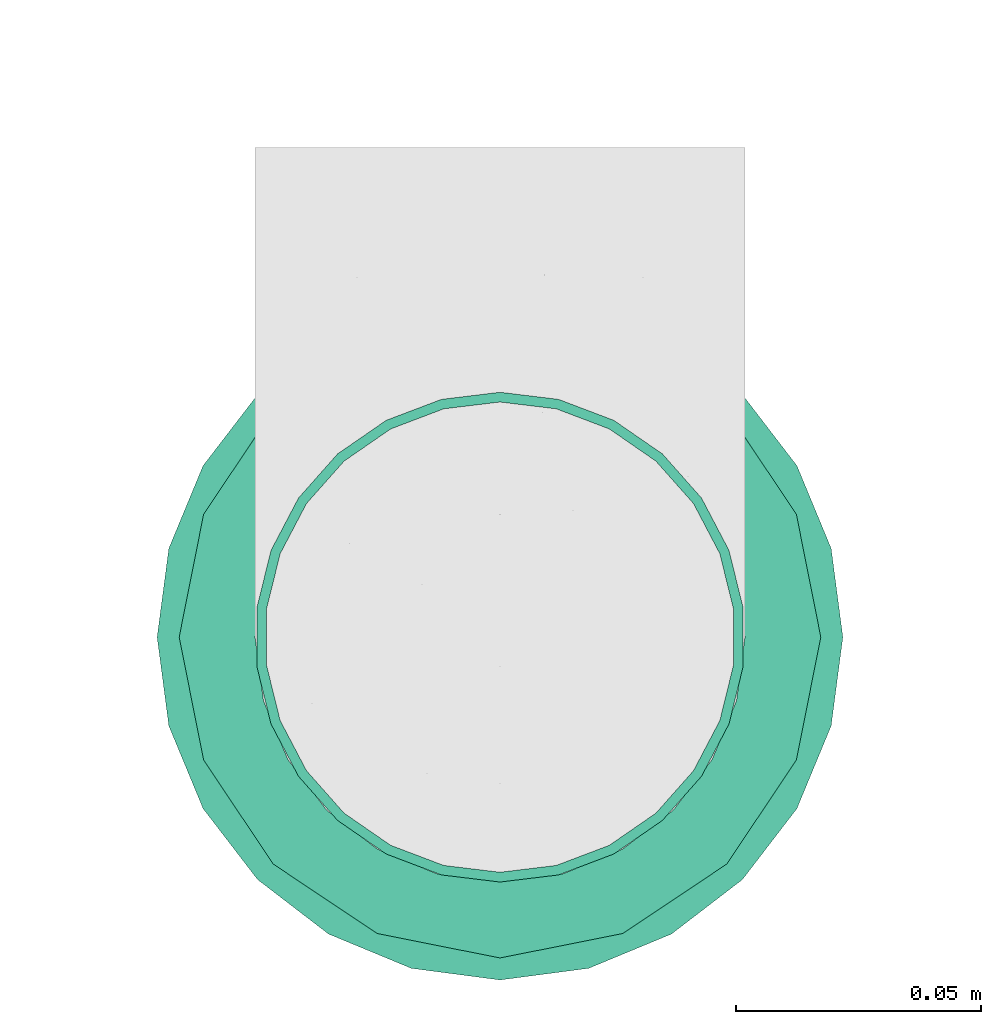
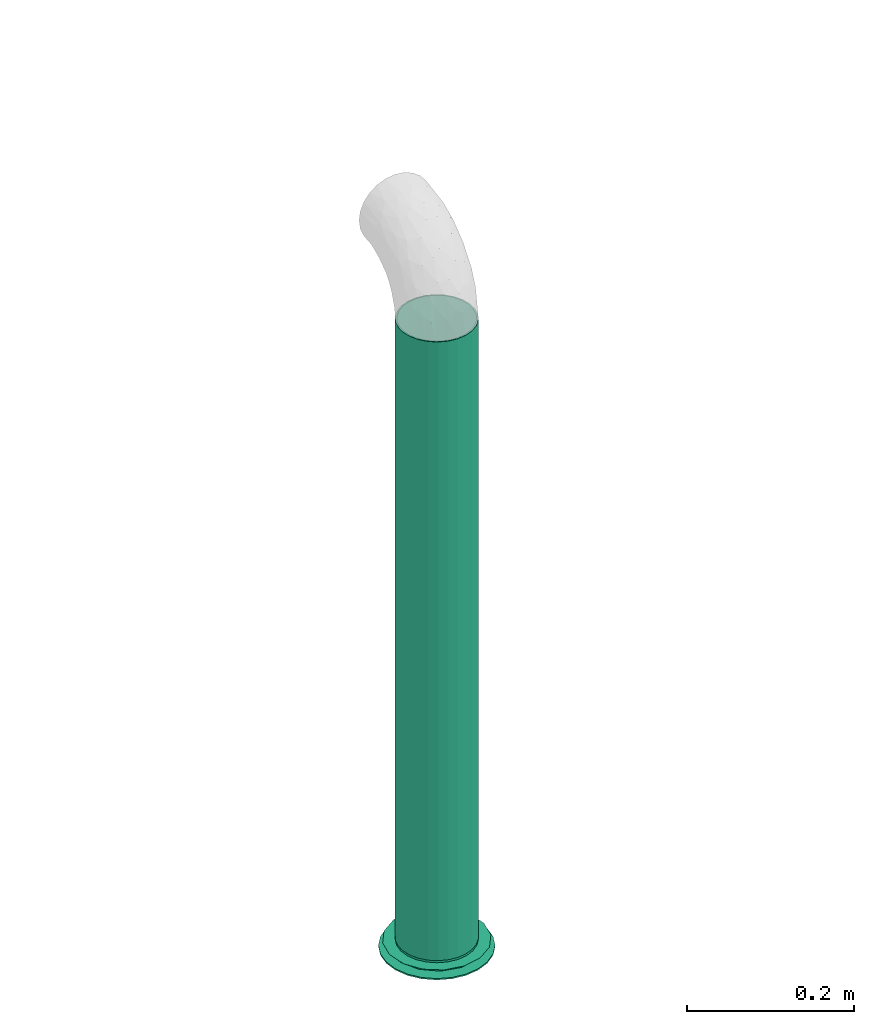
# One storey, part 6 of 103: 1 flow segment, 1 flow terminal.
"""IFC2X3 building model written with IfcOpenShell, lengths in millimetres."""

from ifc_helpers import new_model, entity, si_unit, converted_unit, derived_unit, direction, frame, origin_with_axes, origin_2d_with_axis, place, context, subcontext, project, spatial, hollow_circle, extrude, open_shell, surface_model, source, transform, mapped, material, layer, layer_set, layer_usage, type_object, element, save


model = new_model("IFC2X3")

# Units and contexts
model_context = context("Model", 3, precision=1e-05, world=origin_with_axes(), true_north=direction((0.0, 1.0)))
body_context = subcontext(model_context, "Body", "Model", "MODEL_VIEW")
ifc_project = project(units=[si_unit("AREAUNIT", "SQUARE_METRE"), si_unit("VOLUMEUNIT", "CUBIC_METRE", prefix="DECI"), si_unit("TIMEUNIT", "SECOND"), si_unit("THERMODYNAMICTEMPERATUREUNIT", "DEGREE_CELSIUS"), si_unit("PRESSUREUNIT", "PASCAL"), si_unit("MASSUNIT", "GRAM", prefix="KILO"), si_unit("LENGTHUNIT", "METRE", prefix="MILLI"), si_unit("POWERUNIT", "WATT"), si_unit("ELECTRICCURRENTUNIT", "AMPERE"), si_unit("ELECTRICVOLTAGEUNIT", "VOLT"), derived_unit("VOLUMETRICFLOWRATEUNIT", [(si_unit("VOLUMEUNIT", "CUBIC_METRE", prefix="DECI"), 1), (si_unit("TIMEUNIT", "SECOND"), -1)]), derived_unit("LINEARVELOCITYUNIT", [(si_unit("LENGTHUNIT", "METRE"), 1), (si_unit("TIMEUNIT", "SECOND"), -1)]), derived_unit("MASSDENSITYUNIT", [(si_unit("MASSUNIT", "GRAM", prefix="KILO"), 1), (si_unit("VOLUMEUNIT", "CUBIC_METRE"), -1)]), converted_unit("PLANEANGLEUNIT", "DEGREE", entity("IfcRatioMeasure", 0.01745), si_unit("PLANEANGLEUNIT", "RADIAN"), dimensions=[0, 0, 0, 0, 0, 0, 0])], contexts=[model_context])

# Site, building, storey
site_placement = place(None, origin_with_axes())
site = spatial("IfcSite", under=ifc_project, at=site_placement, CompositionType="ELEMENT")
building_placement = place(site_placement, origin_with_axes())
building = spatial("IfcBuilding", under=site, at=building_placement, Name="mc-building", CompositionType="ELEMENT")
storey_placement = place(building_placement, frame((0.0, 0.0, 5900.0), z_axis=(0.0, 0.0, 1.0), x_axis=(1.0, 0.0, 0.0)))
storey = spatial("IfcBuildingStorey", under=building, at=storey_placement, Name="3. Korrus", CompositionType="ELEMENT", Elevation=5900.0)

# Flow segment
ifc_material = material(Name="FZ1")
ifc_layer = layer(ifc_material, 0.0)
ifc_layer_set = layer_set([ifc_layer], Name="FZ1")
ifc_layer_usage = layer_usage(ifc_layer_set, "AXIS1", "POSITIVE", 0.0)
duct_segment_type = type_object("IfcDuctSegmentType", Name="Safe", PredefinedType="RIGIDSEGMENT")
shared_shape_1 = source(origin_with_axes(), body_context, "Body", "SweptSolid", [
    extrude(hollow_circle(Radius=50.0, WallThickness=2.0, at=origin_2d_with_axis()), frame((0.0, 0.0, 0.0), z_axis=(1.0, 0.0, 0.0), x_axis=(0.0, 1.0, 0.0)), (0.0, 0.0, 1.0), 906.0),
])
flow_segment_placement = place(storey_placement, frame((6000.0, 573.88887, 2461.97044), z_axis=(1.0, 0.0, 0.0), x_axis=(0.0, 0.0, 1.0)))
element("IfcFlowSegment", 1, at=flow_segment_placement, inside=storey, type_object=duct_segment_type, material=ifc_layer_usage, Name="Safe", context=body_context, shape_type="MappedRepresentation", body=[
    mapped(shared_shape_1, transform((0.0, 0.0, 0.0), scale=1.0)),
])

# Flow terminal
air_terminal_type = type_object("IfcAirTerminalType", Name="100", PredefinedType="NOTDEFINED")
shared_shape_2 = source(origin_with_axes(), body_context, "Body", "SurfaceModel", [
    surface_model("IfcShellBasedSurfaceModel", [(11.2, -70.0, 0.0), (11.2, -67.61481, -18.11733), (11.2, -67.61481, 18.11733), (6.2, -14.64625, -20.15883), (9.2, -22.36867, -22.36867), (6.2, -21.19625, -15.39997), (9.2, 16.375, -28.36233), (6.2, 8.09625, -24.91768), (6.2, 14.64625, -20.15883), (6.2, -8.09625, -24.91768), (9.2, -16.375, -28.36233), (6.2, 21.19625, -15.39997), (9.2, 22.36867, -22.36867), (9.2, -8.1875, -30.55617), (9.2, 8.1875, -30.55617), (9.2, 28.36233, -16.375), (9.2, -28.36233, -16.375), (6.2, 14.64625, 20.15883), (9.2, 22.36867, 22.36867), (6.2, 21.19625, 15.39997), (9.2, -16.375, 28.36233), (6.2, -8.09625, 24.91768), (6.2, -14.64625, 20.15883), (6.2, 8.09625, 24.91768), (9.2, 16.375, 28.36233), (6.2, -21.19625, 15.39997), (9.2, -22.36867, 22.36867), (9.2, 8.1875, 30.55617), (9.2, -8.1875, 30.55617), (9.2, -28.36233, 16.375), (9.2, 28.36233, 16.375), (6.2, -53.11211, -25.57744), (6.2, -36.75472, -46.08897), (6.2, -13.11761, -57.472), (6.2, 13.11761, -57.472), (6.2, 36.75472, -46.08897), (6.2, 53.11211, -25.57744), (0.0, -12.53288, -63.00706), (6.2, 0.0, -57.472), (0.0, -46.3155, -46.3155), (0.0, -35.69063, -53.4148), (0.0, 0.0, -65.5), (6.2, 44.93342, -35.83321), (0.0, 46.3155, -46.3155), (0.0, 35.69063, -53.4148), (6.2, -44.93342, -35.83321), (0.0, 12.53288, -63.00706), (0.0, 25.06576, -60.51411), (6.2, 56.03105, -12.78872), (0.0, 60.51411, -25.06576), (0.0, 63.00706, -12.53288), (0.0, 53.4148, -35.69063), (0.0, -25.06576, -60.51411), (0.0, -63.00706, -12.53288), (0.0, -60.51411, -25.06576), (6.2, -56.03105, -12.78872), (0.0, -53.4148, -35.69063), (6.2, 13.11761, 57.472), (0.0, 12.53288, 63.00706), (6.2, 0.0, 57.472), (6.2, 36.75472, 46.08897), (0.0, 46.3155, 46.3155), (0.0, 35.69063, 53.4148), (0.0, 0.0, 65.5), (6.2, -44.93342, 35.83321), (6.2, -36.75472, 46.08897), (0.0, -46.3155, 46.3155), (0.0, -35.69063, 53.4148), (6.2, 44.93342, 35.83321), (0.0, -12.53288, 63.00706), (0.0, -25.06576, 60.51411), (6.2, -13.11761, 57.472), (6.2, -56.03105, 12.78872), (0.0, -60.51411, 25.06576), (0.0, -63.00706, 12.53288), (0.0, -53.4148, 35.69063), (0.0, 25.06576, 60.51411), (0.0, 63.00706, 12.53288), (0.0, 60.51411, 25.06576), (6.2, 56.03105, 12.78872), (0.0, 53.4148, 35.69063), (-3.1, 43.30127, 25.0), (-3.1, -48.29629, -12.94095), (-3.1, -43.30127, 25.0), (-3.1, 25.0, -43.30127), (-3.1, 48.29629, -12.94095), (-3.1, 35.35534, -35.35534), (-3.1, -35.35534, -35.35534), (-3.1, -25.0, -43.30127), (-43.1, 43.46666, 11.64686), (-3.1, 38.97115, 22.5), (-3.1, 43.46666, 11.64686), (-3.1, 45.0, 0.0), (-43.1, 45.0, 0.0), (-3.1, 31.81981, 31.81981), (-43.1, 38.97115, 22.5), (-43.1, -38.97115, 22.5), (-3.1, -38.97115, 22.5), (-3.1, -31.81981, 31.81981), (-3.1, -43.46666, 11.64686), (-43.1, -43.46666, 11.64686), (-43.1, -45.0, 0.0), (-3.1, -45.0, 0.0), (-43.1, -43.46666, -11.64686), (-3.1, -38.97115, -22.5), (-3.1, -43.46666, -11.64686), (-3.1, -11.64686, -43.46666), (-3.1, -22.5, -38.97115), (-43.1, -22.5, -38.97115), (-3.1, -31.81981, -31.81981), (-43.1, -38.97115, -22.5), (-43.1, 22.5, -38.97115), (-3.1, 22.5, -38.97115), (-3.1, 11.64686, -43.46666), (-43.1, 38.97115, -22.5), (-3.1, 38.97115, -22.5), (-3.1, 31.81981, -31.81981), (-3.1, 43.46666, -11.64686), (-43.1, 43.46666, -11.64686), (11.2, -49.49747, -49.49747), (11.2, -35.0, -60.62178), (11.2, -18.11733, -67.61481), (11.2, 67.61481, 18.11733), (11.2, -60.62178, -35.0), (11.2, 18.11733, -67.61481), (11.2, 35.0, -60.62178), (11.2, 0.0, -70.0), (11.2, 60.62178, -35.0), (11.2, 67.61481, -18.11733), (11.2, 49.49747, -49.49747), (11.2, -49.49747, 49.49747), (11.2, -60.62178, 35.0), (11.2, -35.0, 60.62178), (11.2, -18.11733, 67.61481), (11.2, 0.0, 70.0), (11.2, 60.62178, 35.0), (11.2, 49.49747, 49.49747), (11.2, 70.0, 0.0), (11.2, 35.0, 60.62178), (11.2, 18.11733, 67.61481), (9.2, -49.49747, 49.49747), (9.2, -35.0, 60.62178), (9.2, -18.11733, 67.61481), (9.2, -67.61481, 18.11733), (9.2, -70.0, 0.0), (9.2, -60.62178, 35.0), (9.2, 67.61481, 18.11733), (9.2, 35.0, 60.62178), (9.2, 18.11733, 67.61481), (9.2, 0.0, 70.0), (9.2, 60.62178, 35.0), (9.2, 49.49747, 49.49747), (9.2, -67.61481, -18.11733), (9.2, -49.49747, -49.49747), (9.2, -60.62178, -35.0), (9.2, -18.11733, -67.61481), (9.2, 70.0, 0.0), (9.2, -35.0, -60.62178), (9.2, 0.0, -70.0), (9.2, 60.62178, -35.0), (9.2, 49.49747, -49.49747), (9.2, 67.61481, -18.11733), (9.2, 35.0, -60.62178), (9.2, 18.11733, -67.61481), (9.2, -32.75, 0.0), (9.2, 0.0, 32.75), (9.2, 32.75, 0.0), (9.2, 0.0, -32.75), (6.2, 26.2, 0.0), (6.2, -26.2, 0.0), (9.2, -31.06579, -6.28555), (6.2, -23.69812, -7.69999), (6.2, 23.69812, -7.69999), (9.2, 31.06579, -6.28555), (6.2, 0.0, -24.91768), (9.2, 31.06579, 6.28555), (6.2, 23.69812, 7.69999), (6.2, -23.69812, 7.69999), (9.2, -31.06579, 6.28555), (6.2, 0.0, 24.91768), (6.2, 53.11211, 25.57744), (6.2, 58.95, 0.0), (6.2, -53.11211, 25.57744), (6.2, -58.95, 0.0), (0.0, 65.5, 0.0), (0.0, -65.5, 0.0), (6.2, -24.93616, -51.78048), (6.2, 24.93616, -51.78048), (6.2, 24.93616, 51.78048), (6.2, -24.93616, 51.78048), (-3.1, 0.0, 50.0), (-3.1, 35.35534, 35.35534), (-3.1, -12.94095, 48.29629), (-3.1, -25.0, 43.30127), (-3.1, -35.35534, 35.35534), (-3.1, 25.0, 43.30127), (-3.1, 12.94095, 48.29629), (-3.1, 48.29629, 12.94095), (-3.1, 50.0, 0.0), (-3.1, -50.0, 0.0), (-3.1, -48.29629, 12.94095), (-3.1, -43.30127, -25.0), (-3.1, -12.94095, -48.29629), (-3.1, 0.0, -50.0), (-3.1, 43.30127, -25.0), (-3.1, 12.94095, -48.29629), (0.0, -12.94095, -48.29629), (0.0, 0.0, -50.0), (0.0, -25.0, -43.30127), (0.0, -35.35534, -35.35534), (0.0, -48.29629, -12.94095), (0.0, 25.0, -43.30127), (0.0, -43.30127, -25.0), (0.0, 43.30127, 25.0), (0.0, 12.94095, -48.29629), (0.0, 43.30127, -25.0), (0.0, 48.29629, -12.94095), (0.0, 35.35534, -35.35534), (0.0, 50.0, 0.0), (0.0, -50.0, 0.0), (0.0, -48.29629, 12.94095), (0.0, -43.30127, 25.0), (0.0, -35.35534, 35.35534), (0.0, -12.94095, 48.29629), (0.0, -25.0, 43.30127), (0.0, 35.35534, 35.35534), (0.0, 0.0, 50.0), (0.0, 48.29629, 12.94095), (0.0, 25.0, 43.30127), (0.0, 12.94095, 48.29629), (-43.1, -22.5, 38.97115), (-43.1, -11.64686, 43.46666), (-43.1, 0.0, 45.0), (-43.1, 11.64686, 43.46666), (-43.1, -31.81981, 31.81981), (-43.1, 31.81981, 31.81981), (-43.1, 22.5, 38.97115), (-43.1, -31.81981, -31.81981), (-43.1, 31.81981, -31.81981), (-43.1, -11.64686, -43.46666), (-43.1, 11.64686, -43.46666), (-43.1, 0.0, -45.0), (-3.1, 0.0, -45.0), (-3.1, 0.0, 45.0), (-3.1, -22.5, 38.97115), (-3.1, -11.64686, 43.46666), (-3.1, 11.64686, 43.46666), (-3.1, 22.5, 38.97115)], [open_shell([[[0, 1, 2]], [[3, 4, 5]], [[6, 7, 8]], [[3, 9, 10]], [[4, 3, 10]], [[11, 12, 8]], [[13, 10, 9]], [[7, 6, 14]], [[6, 8, 12]], [[12, 11, 15]], [[16, 5, 4]], [[17, 18, 19]], [[20, 21, 22]], [[17, 23, 24]], [[18, 17, 24]], [[25, 26, 22]], [[27, 24, 23]], [[21, 20, 28]], [[20, 22, 26]], [[26, 25, 29]], [[30, 19, 18]], [[31, 32, 33]], [[34, 35, 36]], [[33, 37, 38]], [[32, 39, 40]], [[41, 38, 37]], [[42, 35, 43]], [[44, 43, 35]], [[39, 32, 45]], [[46, 47, 34]], [[48, 49, 50]], [[38, 46, 34]], [[42, 43, 51]], [[33, 52, 37]], [[53, 54, 55]], [[46, 38, 41]], [[56, 39, 45]], [[57, 58, 59]], [[60, 61, 62]], [[63, 59, 58]], [[64, 65, 66]], [[67, 66, 65]], [[61, 60, 68]], [[69, 70, 71]], [[72, 73, 74]], [[59, 69, 71]], [[64, 66, 75]], [[57, 76, 58]], [[77, 78, 79]], [[69, 59, 63]], [[80, 61, 68]], [[81, 82, 83]], [[84, 85, 86]], [[87, 82, 88]], [[89, 90, 91]], [[91, 92, 93]], [[94, 90, 95]], [[96, 97, 98]], [[99, 97, 100]], [[101, 102, 99]], [[103, 104, 105]], [[105, 102, 101]], [[106, 107, 108]], [[109, 104, 110]], [[111, 112, 113]], [[114, 115, 116]], [[117, 115, 118]], [[93, 92, 117]], [[119, 120, 121]], [[1, 119, 121]], [[122, 1, 121]], [[123, 119, 1]], [[124, 122, 121]], [[125, 122, 124]], [[121, 126, 124]], [[127, 128, 129]], [[129, 128, 122]], [[129, 122, 125]], [[130, 131, 2]], [[132, 130, 2]], [[122, 133, 2]], [[132, 2, 133]], [[134, 133, 122]], [[135, 136, 122]], [[122, 128, 137]], [[136, 138, 122]], [[139, 122, 138]], [[122, 139, 134]], [[2, 1, 122]], [[140, 141, 142]], [[143, 140, 142]], [[142, 144, 143]], [[145, 140, 143]], [[146, 144, 142]], [[147, 146, 148]], [[149, 148, 146]], [[150, 146, 151]], [[147, 151, 146]], [[146, 142, 149]], [[146, 152, 144]], [[153, 154, 152]], [[155, 153, 152]], [[146, 156, 155]], [[157, 153, 155]], [[158, 155, 156]], [[159, 160, 161]], [[156, 161, 160]], [[160, 162, 156]], [[163, 156, 162]], [[163, 158, 156]], [[152, 146, 155]], [[156, 128, 161]], [[161, 127, 159]], [[162, 160, 125]], [[129, 160, 159]], [[163, 162, 124]], [[128, 127, 161]], [[156, 137, 128]], [[162, 125, 124]], [[125, 160, 129]], [[159, 127, 129]], [[163, 124, 126]], [[126, 158, 163]], [[158, 121, 155]], [[155, 120, 157]], [[154, 153, 123]], [[119, 153, 157]], [[152, 154, 1]], [[120, 119, 157]], [[155, 121, 120]], [[152, 1, 0]], [[1, 154, 123]], [[153, 119, 123]], [[152, 0, 144]], [[126, 121, 158]], [[144, 2, 143]], [[143, 131, 145]], [[141, 140, 132]], [[130, 140, 145]], [[142, 141, 133]], [[2, 131, 143]], [[144, 0, 2]], [[141, 132, 133]], [[132, 140, 130]], [[145, 131, 130]], [[142, 133, 134]], [[134, 149, 142]], [[149, 139, 148]], [[148, 138, 147]], [[150, 151, 135]], [[136, 151, 147]], [[146, 150, 122]], [[138, 136, 147]], [[148, 139, 138]], [[146, 122, 137]], [[122, 150, 135]], [[151, 136, 135]], [[146, 137, 156]], [[134, 139, 149]], [[30, 24, 164]], [[24, 20, 164]], [[165, 20, 24]], [[164, 20, 29]], [[166, 30, 16]], [[16, 6, 166]], [[167, 6, 10]], [[30, 164, 16]], [[10, 6, 16]], [[6, 15, 166]], [[21, 19, 11]], [[23, 19, 21]], [[11, 19, 168]], [[7, 25, 21]], [[7, 5, 169]], [[21, 11, 7]], [[9, 5, 7]], [[169, 25, 7]], [[170, 164, 169]], [[170, 171, 16]], [[11, 172, 15]], [[172, 168, 173]], [[174, 13, 9]], [[166, 173, 168]], [[172, 173, 15]], [[169, 171, 170]], [[5, 16, 171]], [[167, 174, 14]], [[174, 167, 13]], [[14, 174, 7]], [[175, 166, 168]], [[175, 176, 30]], [[25, 177, 29]], [[177, 169, 178]], [[179, 27, 23]], [[164, 178, 169]], [[177, 178, 29]], [[168, 176, 175]], [[19, 30, 176]], [[165, 179, 28]], [[179, 165, 27]], [[28, 179, 21]], [[180, 60, 57]], [[181, 180, 65]], [[65, 57, 71]], [[180, 57, 65]], [[65, 182, 181]], [[182, 36, 181]], [[183, 34, 36]], [[31, 34, 183]], [[31, 33, 34]], [[182, 183, 36]], [[70, 63, 49]], [[70, 73, 66]], [[49, 63, 184]], [[78, 76, 61]], [[76, 78, 184]], [[184, 63, 76]], [[73, 70, 49]], [[39, 54, 185]], [[41, 39, 185]], [[52, 39, 41]], [[43, 185, 49]], [[185, 43, 47]], [[185, 47, 41]], [[73, 49, 185]], [[55, 54, 31]], [[31, 54, 56]], [[52, 186, 40]], [[53, 55, 183]], [[56, 45, 31]], [[185, 53, 183]], [[32, 40, 186]], [[33, 186, 52]], [[44, 35, 187]], [[49, 36, 51]], [[34, 47, 187]], [[42, 51, 36]], [[187, 47, 44]], [[49, 48, 36]], [[48, 50, 181]], [[184, 181, 50]], [[79, 78, 180]], [[180, 78, 80]], [[76, 188, 62]], [[77, 79, 181]], [[80, 68, 180]], [[184, 77, 181]], [[60, 62, 188]], [[57, 188, 76]], [[67, 65, 189]], [[73, 182, 75]], [[71, 70, 189]], [[64, 75, 182]], [[189, 70, 67]], [[73, 72, 182]], [[72, 74, 183]], [[185, 183, 74]], [[190, 191, 192]], [[193, 192, 194]], [[83, 192, 81]], [[194, 192, 83]], [[195, 191, 196]], [[191, 190, 196]], [[197, 198, 81]], [[81, 192, 191]], [[198, 84, 81]], [[199, 200, 83]], [[81, 88, 82]], [[201, 82, 87]], [[88, 81, 202]], [[81, 203, 202]], [[204, 86, 85]], [[205, 203, 84]], [[84, 198, 85]], [[81, 84, 203]], [[199, 83, 82]], [[206, 207, 208]], [[209, 208, 210]], [[210, 208, 211]], [[212, 209, 210]], [[210, 211, 213]], [[214, 211, 207]], [[211, 208, 207]], [[215, 216, 217]], [[211, 217, 216]], [[216, 218, 211]], [[219, 210, 220]], [[221, 210, 213]], [[222, 221, 223]], [[213, 223, 221]], [[224, 222, 223]], [[223, 225, 226]], [[227, 213, 218]], [[218, 213, 211]], [[228, 229, 225]], [[223, 213, 225]], [[226, 225, 229]], [[221, 220, 210]], [[199, 220, 200]], [[200, 221, 83]], [[193, 194, 224]], [[222, 194, 83]], [[192, 193, 223]], [[220, 221, 200]], [[199, 219, 220]], [[193, 224, 223]], [[224, 194, 222]], [[83, 221, 222]], [[192, 223, 226]], [[226, 190, 192]], [[190, 229, 196]], [[196, 228, 195]], [[81, 191, 213]], [[225, 191, 195]], [[197, 81, 227]], [[228, 225, 195]], [[196, 229, 228]], [[197, 227, 218]], [[227, 81, 213]], [[191, 225, 213]], [[197, 218, 198]], [[226, 229, 190]], [[198, 216, 85]], [[85, 215, 204]], [[84, 86, 211]], [[217, 86, 204]], [[205, 84, 214]], [[216, 215, 85]], [[198, 218, 216]], [[84, 211, 214]], [[211, 86, 217]], [[204, 215, 217]], [[205, 214, 207]], [[207, 203, 205]], [[203, 206, 202]], [[202, 208, 88]], [[201, 87, 212]], [[209, 87, 88]], [[82, 201, 210]], [[208, 209, 88]], [[202, 206, 208]], [[82, 210, 219]], [[210, 201, 212]], [[87, 209, 212]], [[82, 219, 199]], [[207, 206, 203]], [[230, 231, 232]], [[230, 232, 233]], [[230, 100, 96]], [[234, 230, 96]], [[100, 230, 233]], [[235, 89, 236]], [[100, 233, 236]], [[95, 89, 235]], [[118, 89, 93]], [[118, 236, 89]], [[118, 100, 236]], [[110, 103, 101]], [[237, 110, 101]], [[238, 108, 101]], [[237, 101, 108]], [[239, 108, 238]], [[114, 238, 118]], [[238, 101, 118]], [[240, 241, 111]], [[238, 111, 241]], [[238, 241, 239]], [[100, 118, 101]], [[106, 242, 107]], [[107, 112, 109]], [[102, 105, 104]], [[112, 104, 109]], [[92, 104, 117]], [[113, 112, 242]], [[112, 107, 242]], [[115, 117, 116]], [[112, 116, 117]], [[112, 117, 104]], [[92, 102, 104]], [[97, 99, 243]], [[98, 97, 244]], [[243, 245, 244]], [[97, 243, 244]], [[246, 243, 99]], [[90, 94, 91]], [[92, 91, 247]], [[94, 247, 91]], [[247, 99, 92]], [[247, 246, 99]], [[102, 92, 99]], [[101, 99, 100]], [[100, 97, 96]], [[230, 234, 244]], [[98, 234, 96]], [[231, 230, 245]], [[245, 230, 244]], [[244, 234, 98]], [[245, 243, 231]], [[243, 232, 231]], [[236, 233, 246]], [[236, 247, 235]], [[89, 95, 90]], [[94, 95, 235]], [[93, 89, 91]], [[232, 246, 233]], [[246, 247, 236]], [[243, 246, 232]], [[247, 94, 235]], [[93, 117, 118]], [[118, 115, 114]], [[111, 238, 112]], [[116, 238, 114]], [[240, 111, 113]], [[112, 238, 116]], [[240, 113, 242]], [[242, 241, 240]], [[108, 239, 106]], [[108, 107, 237]], [[103, 110, 104]], [[109, 110, 237]], [[101, 103, 105]], [[241, 106, 239]], [[242, 106, 241]], [[107, 109, 237]]])]),
])
flow_terminal_placement = place(storey_placement, frame((6000.0, 573.88887, 2458.87044), z_axis=(1.0, 0.0, 0.0), x_axis=(0.0, 0.0, -1.0)))
element("IfcFlowTerminal", 2, at=flow_terminal_placement, inside=storey, type_object=air_terminal_type, Name="100", context=body_context, shape_type="MappedRepresentation", body=[
    mapped(shared_shape_2, transform((0.0, 0.0, 0.0), scale=1.0)),
])

save(model, "model.ifc")
